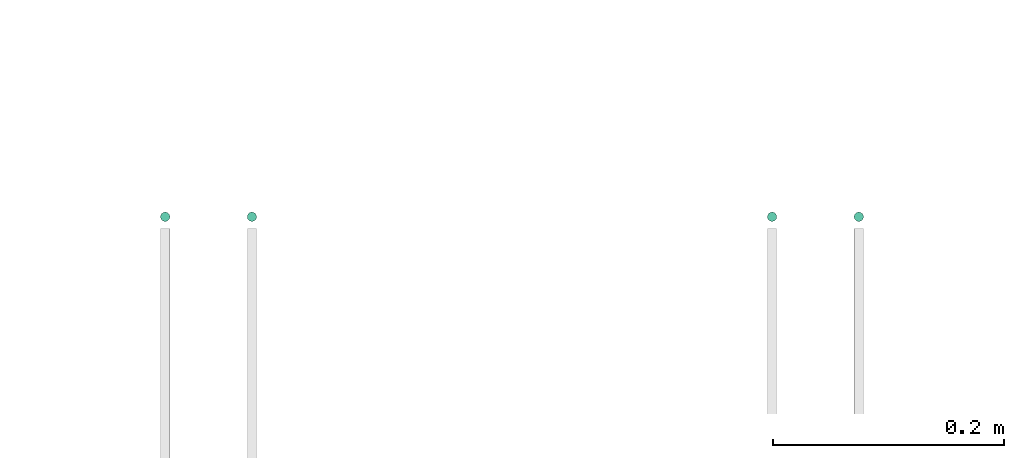
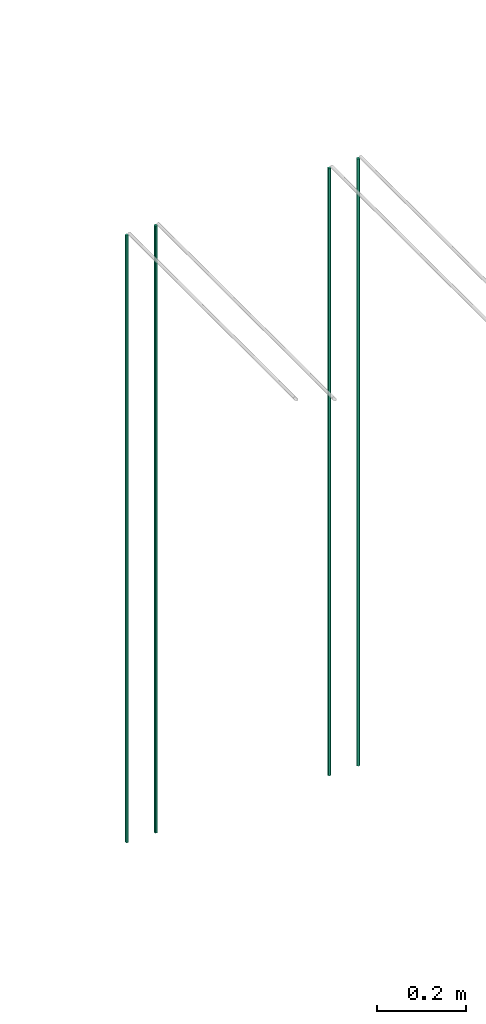
# One storey, part 14 of 89: 4 flow segments.
"""IFC2X3 building model written with IfcOpenShell, lengths in millimetres."""

import ifcopenshell
import ifcopenshell.guid

model = None  # the IFC model being written
_history = None  # IfcOwnerHistory: only IFC2X3 demands one
_inside = {}  # id of a spatial element -> (the spatial element, [elements in it])
_under = {}  # id of a project, library or spatial element -> (it, [spatial elements below it])
_declared = {}  # id of a project -> (the project, [libraries it declares])
_typed = {}  # id of a type object -> (the type object, [elements of that type])
_made_of = {}  # id of a material, layer set ... -> (it, [elements and type objects made of it])


def new_model(schema):
    """Start an empty IFC model of exactly this schema.

    Asked for "IFC4X3", IfcOpenShell would pick the latest addendum, in which some entities
    have other attributes; the version numbers below select the first issue.
    IFC2X3 requires an IfcOwnerHistory on every rooted entity: one is made here for all.
    """
    global model, _history
    if schema == "IFC4X3":
        model = ifcopenshell.file(schema_version=(4, 3, 0, 0))
    else:
        model = ifcopenshell.file(schema=schema)
    _inside.clear()
    _under.clear()
    _declared.clear()
    _typed.clear()
    _made_of.clear()
    _history = None
    if model.schema == "IFC2X3":
        org = make("IfcOrganization", Name="unknown")
        user = make(
            "IfcPersonAndOrganization",
            ThePerson=make("IfcPerson", FamilyName="unknown"),
            TheOrganization=org,
        )
        app = make(
            "IfcApplication",
            ApplicationDeveloper=org,
            Version="unknown",
            ApplicationFullName="unknown",
            ApplicationIdentifier="unknown",
        )
        _history = make(
            "IfcOwnerHistory",
            OwningUser=user,
            OwningApplication=app,
            ChangeAction="ADDED",
            CreationDate=0,
        )
    return model


def make(cls, **values):
    """One entity of the class cls with the attributes given. An attribute that is None is left unset."""
    return model.create_entity(
        cls, **{name: value for name, value in values.items() if value is not None}
    )


def entity(cls, *values):
    """Any entity or typed value of the class cls, its attributes in the order of the schema. None: left unset."""
    e = model.create_entity(cls)
    for i, value in enumerate(values):
        if value is not None:
            e[i] = value
    return e


def rooted(cls, **values):
    """An entity with a GlobalId (a new one), such as an element, a storey or a relation."""
    return make(cls, GlobalId=ifcopenshell.guid.new(), OwnerHistory=_history, **values)


def si_unit(unit_type, name, prefix=None):
    """IfcSIUnit, for example si_unit("LENGTHUNIT", "METRE", prefix="MILLI")."""
    return make("IfcSIUnit", UnitType=unit_type, Prefix=prefix, Name=name)


def converted_unit(unit_type, name, factor, base, dimensions=None, offset=None):
    """IfcConversionBasedUnit, such as the inch: factor (a typed value) times the base unit."""
    return make(
        "IfcConversionBasedUnit"
        if offset is None
        else "IfcConversionBasedUnitWithOffset",
        ConversionOffset=offset,
        Dimensions=None
        if dimensions is None
        else entity("IfcDimensionalExponents", *dimensions),
        UnitType=unit_type,
        Name=name,
        ConversionFactor=make(
            "IfcMeasureWithUnit", ValueComponent=factor, UnitComponent=base
        ),
    )


def derived_unit(unit_type, elements):
    """IfcDerivedUnit: a product of units, each with its exponent."""
    return make(
        "IfcDerivedUnit",
        Elements=[
            make("IfcDerivedUnitElement", Unit=unit, Exponent=power)
            for unit, power in elements
        ],
        UnitType=unit_type,
    )


def assignment(units):
    """IfcUnitAssignment: the units of a project."""
    return None if units is None else make("IfcUnitAssignment", Units=units)


def point(xyz):
    """IfcCartesianPoint."""
    return None if xyz is None else make("IfcCartesianPoint", Coordinates=xyz)


def direction(xyz):
    """IfcDirection."""
    return None if xyz is None else make("IfcDirection", DirectionRatios=xyz)


def frame(location, z_axis=None, x_axis=None):
    """IfcAxis2Placement3D, a coordinate frame: its origin and axes. An axis left out is left unset."""
    return make(
        "IfcAxis2Placement3D",
        Location=point(location),
        Axis=direction(z_axis),
        RefDirection=direction(x_axis),
    )


def frame_2d(location, x_axis=None):
    """IfcAxis2Placement2D, a coordinate frame in the plane: its origin and x axis."""
    return make(
        "IfcAxis2Placement2D", Location=point(location), RefDirection=direction(x_axis)
    )


def origin():
    """The frame at (0, 0, 0) with its axes left unset."""
    return frame((0.0, 0.0, 0.0))


def origin_2d_with_axis():
    """The frame at (0, 0) in the plane with the x axis (1, 0) written out."""
    return frame_2d((0.0, 0.0), x_axis=(1.0, 0.0))


def place(relative_to, where):
    """IfcLocalPlacement: puts the frame where relative to a parent placement (None: the world)."""
    return make(
        "IfcLocalPlacement", PlacementRelTo=relative_to, RelativePlacement=where
    )


def context(
    kind, dimensions, precision=None, world=None, true_north=None, identifier=None
):
    """IfcGeometricRepresentationContext, for example the 3D "Model" context."""
    return make(
        "IfcGeometricRepresentationContext",
        ContextIdentifier=identifier,
        ContextType=kind,
        CoordinateSpaceDimension=dimensions,
        Precision=precision,
        WorldCoordinateSystem=world,
        TrueNorth=true_north,
    )


def subcontext(parent, identifier, kind, view, scale=None):
    """IfcGeometricRepresentationSubContext, for example "Body" below "Model"."""
    return make(
        "IfcGeometricRepresentationSubContext",
        ContextIdentifier=identifier,
        ContextType=kind,
        ParentContext=parent,
        TargetScale=scale,
        TargetView=view,
    )


def project(units=None, contexts=None):
    """IfcProject with its units and contexts."""
    return rooted(
        "IfcProject",
        Name="project",
        RepresentationContexts=contexts,
        UnitsInContext=assignment(units),
    )


def spatial(cls, under=None, at=None, **own):
    """A site, building, storey or space (cls), placed at a placement, below another one or the project."""
    s = rooted(cls, ObjectPlacement=at, **own)
    if under is not None:
        _under.setdefault(under.id(), (under, []))[1].append(s)
    return s


def profile(cls, at=None, kind="AREA", **sizes):
    """A parametric profile (cls). Its sizes go by their IFC names, for example OverallWidth=200.0."""
    return make(cls, ProfileType=kind, Position=at, **sizes)


def circle(**sizes):
    """IfcCircleProfileDef."""
    return profile("IfcCircleProfileDef", **sizes)


def extrude(swept, where, along, depth):
    """IfcExtrudedAreaSolid: the profile swept, set in the frame where, extruded along a direction by depth."""
    return make(
        "IfcExtrudedAreaSolid",
        SweptArea=swept,
        Position=where,
        ExtrudedDirection=direction(along),
        Depth=depth,
    )


def shape(context_of_items, identifier, shape_type, items):
    """IfcShapeRepresentation: the items that make up one representation, for example the "Body"."""
    return make(
        "IfcShapeRepresentation",
        ContextOfItems=context_of_items,
        RepresentationIdentifier=identifier,
        RepresentationType=shape_type,
        Items=items,
    )


def made_of(thing, what):
    """Note that an element or type object is made of a material, layer set ...; save() writes the relation."""
    if what is not None:
        _made_of.setdefault(what.id(), (what, []))[1].append(thing)
    return thing


def type_object(cls, material=None, **own):
    """A type object (cls), such as IfcWallType, which elements share."""
    return made_of(rooted(cls, **own), material)


def element(
    cls,
    number,
    at=None,
    inside=None,
    cuts=None,
    type_object=None,
    material=None,
    context=None,
    identifier="Body",
    shape_type=None,
    held_by="IfcProductDefinitionShape",
    body=None,
    shapes=None,
    **own,
):
    """One element of the class cls, such as IfcWall. Its Tag is "e" and its number.

    at: its placement. inside: the storey or other place that contains it. cuts: it is an
    opening in that element (IfcRelVoidsElement). A single representation is given by context,
    identifier, shape_type and body (its items); several are given by shapes. held_by: the class
    of the entity that holds the representations. save() writes the other relations.
    """
    e = rooted(cls, Tag="e%d" % number, ObjectPlacement=at, **own)
    if body is not None:
        shapes = [shape(context, identifier, shape_type, body)]
    if shapes is not None:
        e.Representation = make(held_by, Representations=shapes)
    if inside is not None:
        _inside.setdefault(inside.id(), (inside, []))[1].append(e)
    if cuts is not None:
        rooted(
            "IfcRelVoidsElement", RelatingBuildingElement=cuts, RelatedOpeningElement=e
        )
    if type_object is not None:
        _typed.setdefault(type_object.id(), (type_object, []))[1].append(e)
    return made_of(e, material)


def aggregate(whole, parts):
    """IfcRelAggregates: a whole, such as a stair, and the parts it consists of."""
    return rooted("IfcRelAggregates", RelatingObject=whole, RelatedObjects=parts)


def save(model, path):
    """Write the relations noted so far, then the file.

    IfcRelAggregates (storeys below a building ...), IfcRelContainedInSpatialStructure (elements
    in a storey), IfcRelDefinesByType, IfcRelAssociatesMaterial and IfcRelDeclares: one each for
    every whole, place, type object, material and project.
    """
    for whole, parts in _under.values():
        aggregate(whole, parts)
    for where, things in _inside.values():
        rooted(
            "IfcRelContainedInSpatialStructure",
            RelatedElements=things,
            RelatingStructure=where,
        )
    for kind, things in _typed.values():
        rooted("IfcRelDefinesByType", RelatedObjects=things, RelatingType=kind)
    for what, things in _made_of.values():
        rooted("IfcRelAssociatesMaterial", RelatedObjects=things, RelatingMaterial=what)
    for by, libraries in _declared.values():
        rooted("IfcRelDeclares", RelatingContext=by, RelatedDefinitions=libraries)
    model.write(path)


model = new_model("IFC2X3")

# Units and contexts
model_context = context("Model", 3, precision=0.01, world=origin(), true_north=direction((6.12303176911189e-17, 1.0)))
body_context = subcontext(model_context, "Body", "Model", "MODEL_VIEW")
ifc_project = project(units=[si_unit("LENGTHUNIT", "METRE", prefix="MILLI"), si_unit("AREAUNIT", "SQUARE_METRE"), si_unit("VOLUMEUNIT", "CUBIC_METRE"), converted_unit("PLANEANGLEUNIT", "DEGREE", entity("IfcRatioMeasure", 0.0174532925199433), si_unit("PLANEANGLEUNIT", "RADIAN"), dimensions=[0, 0, 0, 0, 0, 0, 0]), si_unit("MASSUNIT", "GRAM", prefix="KILO"), derived_unit("MASSDENSITYUNIT", [(si_unit("MASSUNIT", "GRAM", prefix="KILO"), 1), (si_unit("LENGTHUNIT", "METRE"), -3)]), derived_unit("MOMENTOFINERTIAUNIT", [(si_unit("LENGTHUNIT", "METRE"), 4)]), si_unit("TIMEUNIT", "SECOND"), si_unit("FREQUENCYUNIT", "HERTZ"), si_unit("THERMODYNAMICTEMPERATUREUNIT", "DEGREE_CELSIUS"), derived_unit("THERMALTRANSMITTANCEUNIT", [(si_unit("MASSUNIT", "GRAM", prefix="KILO"), 1), (si_unit("THERMODYNAMICTEMPERATUREUNIT", "KELVIN"), -1), (si_unit("TIMEUNIT", "SECOND"), -3)]), derived_unit("VOLUMETRICFLOWRATEUNIT", [(si_unit("LENGTHUNIT", "METRE"), 3), (si_unit("TIMEUNIT", "SECOND"), -1)]), derived_unit("MASSFLOWRATEUNIT", [(si_unit("MASSUNIT", "GRAM", prefix="KILO"), 1), (si_unit("TIMEUNIT", "SECOND"), -1)]), derived_unit("ROTATIONALFREQUENCYUNIT", [(si_unit("TIMEUNIT", "SECOND"), -1)]), si_unit("ELECTRICCURRENTUNIT", "AMPERE"), si_unit("ELECTRICVOLTAGEUNIT", "VOLT"), si_unit("POWERUNIT", "WATT"), si_unit("FORCEUNIT", "NEWTON", prefix="KILO"), si_unit("ILLUMINANCEUNIT", "LUX"), si_unit("LUMINOUSFLUXUNIT", "LUMEN"), si_unit("LUMINOUSINTENSITYUNIT", "CANDELA"), derived_unit("USERDEFINED", [(si_unit("MASSUNIT", "GRAM", prefix="KILO"), -1), (si_unit("LENGTHUNIT", "METRE"), -2), (si_unit("TIMEUNIT", "SECOND"), 3), (si_unit("LUMINOUSFLUXUNIT", "LUMEN"), 1)]), derived_unit("LINEARVELOCITYUNIT", [(si_unit("LENGTHUNIT", "METRE"), 1), (si_unit("TIMEUNIT", "SECOND"), -1)]), si_unit("PRESSUREUNIT", "PASCAL"), derived_unit("USERDEFINED", [(si_unit("LENGTHUNIT", "METRE"), -2), (si_unit("MASSUNIT", "GRAM", prefix="KILO"), 1), (si_unit("TIMEUNIT", "SECOND"), -2)]), derived_unit("LINEARFORCEUNIT", [(si_unit("MASSUNIT", "GRAM", prefix="KILO"), 1), (si_unit("LENGTHUNIT", "METRE"), 1), (si_unit("TIMEUNIT", "SECOND"), -2), (si_unit("LENGTHUNIT", "METRE"), -1)]), derived_unit("PLANARFORCEUNIT", [(si_unit("MASSUNIT", "GRAM", prefix="KILO"), 1), (si_unit("LENGTHUNIT", "METRE"), 1), (si_unit("TIMEUNIT", "SECOND"), -2), (si_unit("LENGTHUNIT", "METRE"), -2)])], contexts=[model_context])

# Site, building, storey
site_placement = place(None, frame((0.0, -0.00077364408347762, 0.0)))
site = spatial("IfcSite", under=ifc_project, at=site_placement, CompositionType="ELEMENT")
building_placement = place(site_placement, origin())
building = spatial("IfcBuilding", under=site, at=building_placement, CompositionType="ELEMENT")
storey_placement = place(building_placement, frame((0.0, 0.0, 24000.0)))
storey = spatial("IfcBuildingStorey", under=building, at=storey_placement, CompositionType="ELEMENT", Elevation=24000.0)

# Flow segments
pipe_segment_type = type_object("IfcPipeSegmentType", PredefinedType="NOTDEFINED")
for number, where in (
    (1, (54360.5981151137, 8394.39395908992, 1400.0)),
    (2, (54435.5981151137, 8394.39395908992, 1400.0)),
    (3, (53910.5981151137, 8394.39395908992, 1400.0)),
):
    element("IfcFlowSegment", number, at=place(storey_placement, frame(where)), inside=storey, type_object=pipe_segment_type, context=body_context, shape_type="SweptSolid", body=[
        extrude(circle(Radius=4.0, at=origin_2d_with_axis()), frame((5.59527223591499, 5.59527223591607, 0.0)), (0.0, 0.0, 1.0), 1665.0),
    ])
flow_segment_placement = place(storey_placement, frame((53835.5981151137, 8394.39395908992, 1400.0)))
element("IfcFlowSegment", 4, at=flow_segment_placement, inside=storey, type_object=pipe_segment_type, context=body_context, shape_type="SweptSolid", body=[
    extrude(circle(Radius=4.0, at=frame_2d((0.0, -1.08286712929839e-12), x_axis=(1.0, 0.0))), frame((5.59527223591499, 5.59527223591716, 0.0)), (0.0, 0.0, 1.0), 1665.0),
])

save(model, "model.ifc")
